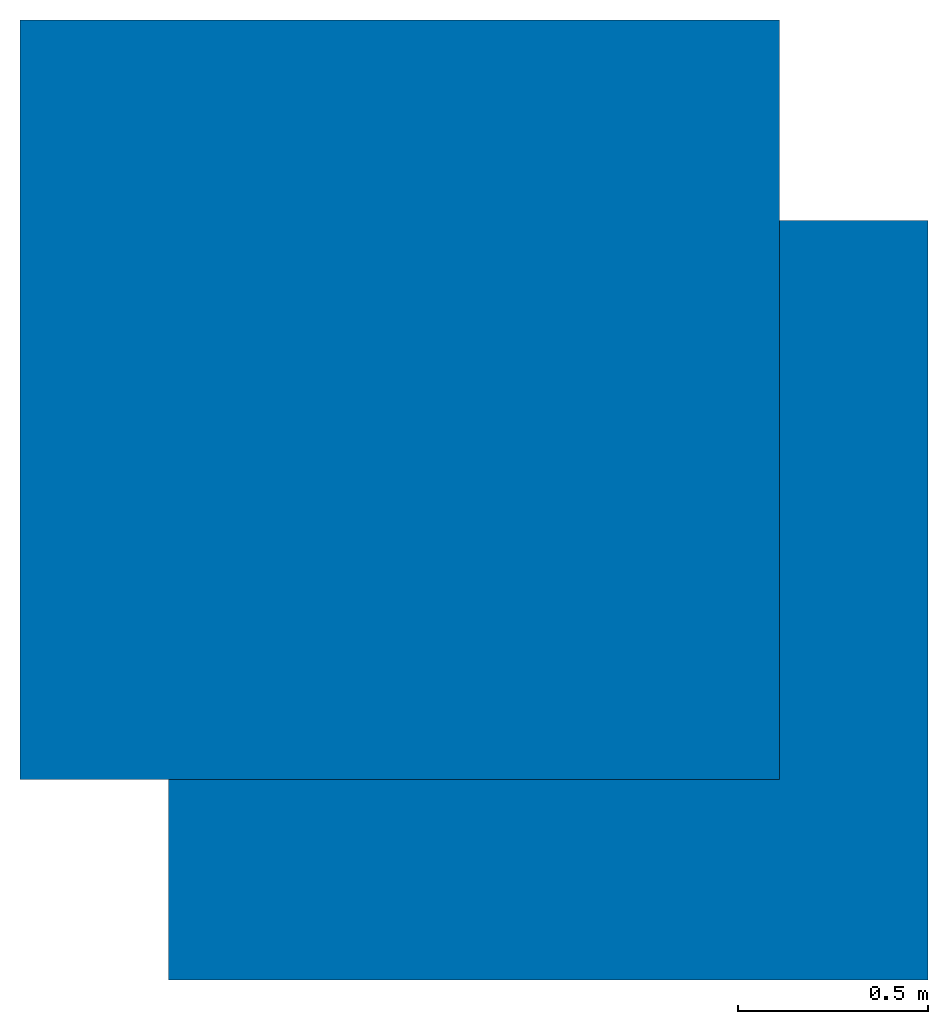
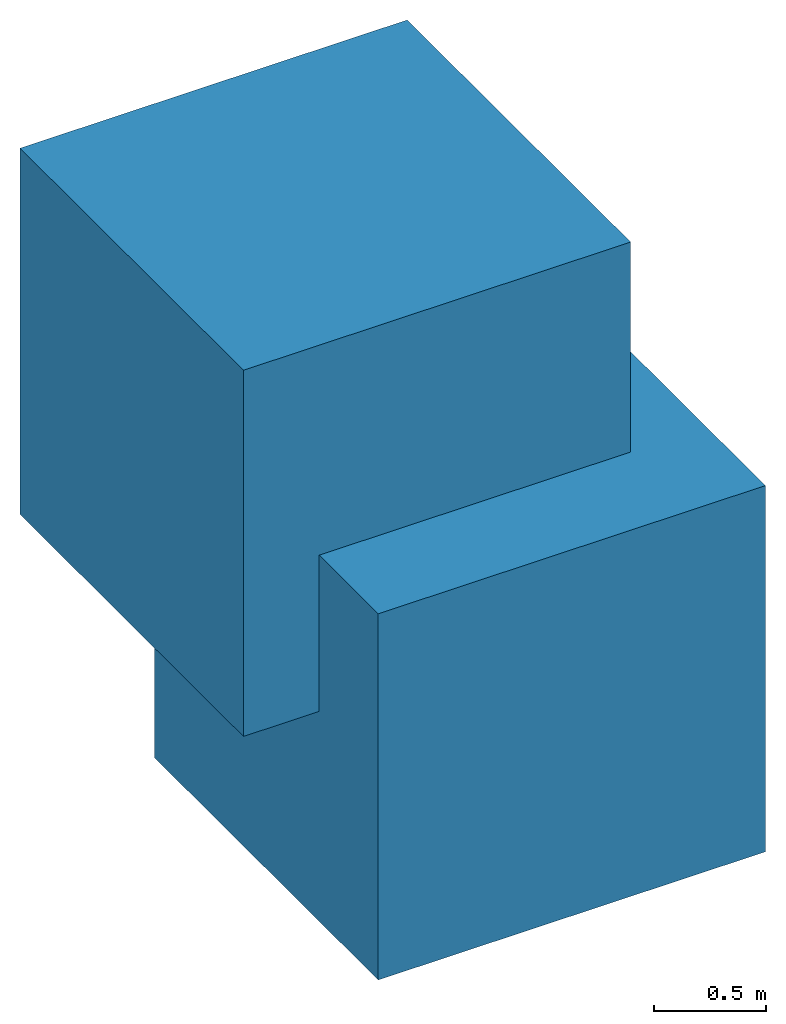
# One storey: 2 walls.
"""IFC4 building model written with IfcOpenShell, lengths in metres."""

from ifc_helpers import new_model, entity, si_unit, converted_unit, frame, frame_2d, origin_with_axes, place, context, subcontext, project, spatial, polygons, element, save


model = new_model("IFC4")

# Units and contexts
model_context = context("Model", 3, precision=1e-05, world=origin_with_axes())
plan_context = context("Plan", 2, precision=1e-05, world=frame_2d((0.0, 0.0, 0.0), x_axis=(1.0, 0.0, 0.0)))
body_context = subcontext(model_context, "Body", "Model", "MODEL_VIEW")
ifc_project = project(units=[converted_unit("PLANEANGLEUNIT", "degree", entity("IfcReal", 0.0174532925199433), si_unit("PLANEANGLEUNIT", "RADIAN"), dimensions=[0, 0, 0, 0, 0, 0, 0]), si_unit("AREAUNIT", "SQUARE_METRE"), si_unit("VOLUMEUNIT", "CUBIC_METRE"), si_unit("LENGTHUNIT", "METRE")], contexts=[model_context, plan_context])

# Site, building, storey
site_placement = place(None, origin_with_axes())
site = spatial("IfcSite", under=ifc_project, at=site_placement)
building_placement = place(site_placement, origin_with_axes())
building = spatial("IfcBuilding", under=site, at=building_placement, Name="Building")
storey_placement = place(building_placement, origin_with_axes())
storey = spatial("IfcBuildingStorey", under=building, at=storey_placement, Name="Storey")

# Walls
for number, where, z_axis, x_axis, name in (
    (1, (-0.391043961048126, 0.528201222419739, 1.14678597450256), (0.0, 0.0, 1.0), (1.0, 0.0, 0.0), "Cube2"),
    (2, (0.0, 0.0, 0.0), (0.0, 0.0, 1.0), (1.0, 0.0, 0.0), "Cube1"),
):
    element("IfcWall", number, at=place(storey_placement, frame(where, z_axis=z_axis, x_axis=x_axis)), inside=storey, Name=name, PredefinedType="ELEMENTEDWALL", context=body_context, shape_type="Tessellation", body=[
        polygons([(-1.0, -1.0, -1.0), (-1.0, -1.0, 1.0), (-1.0, 1.0, -1.0), (-1.0, 1.0, 1.0), (1.0, -1.0, -1.0), (1.0, -1.0, 1.0), (1.0, 1.0, -1.0), (1.0, 1.0, 1.0)], [[[1, 2, 4, 3]], [[3, 4, 8, 7]], [[7, 8, 6, 5]], [[5, 6, 2, 1]], [[3, 7, 5, 1]], [[8, 4, 2, 6]]]),
    ])

save(model, "model.ifc")
